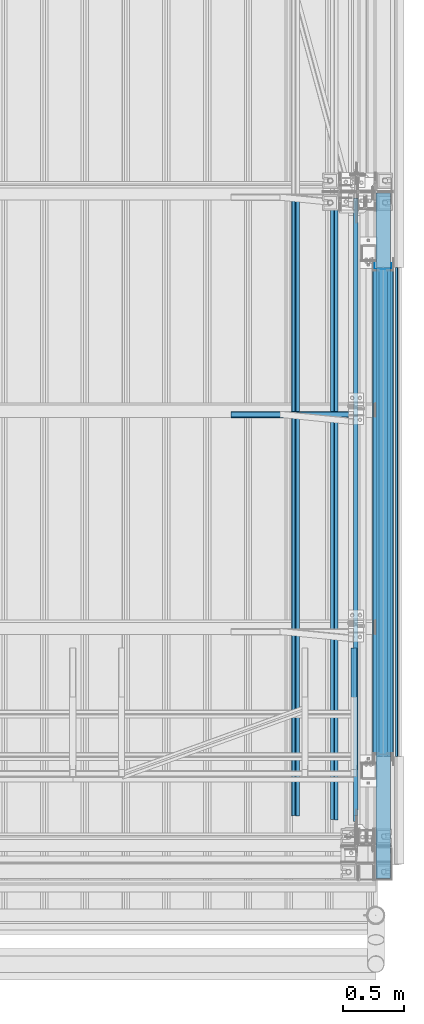
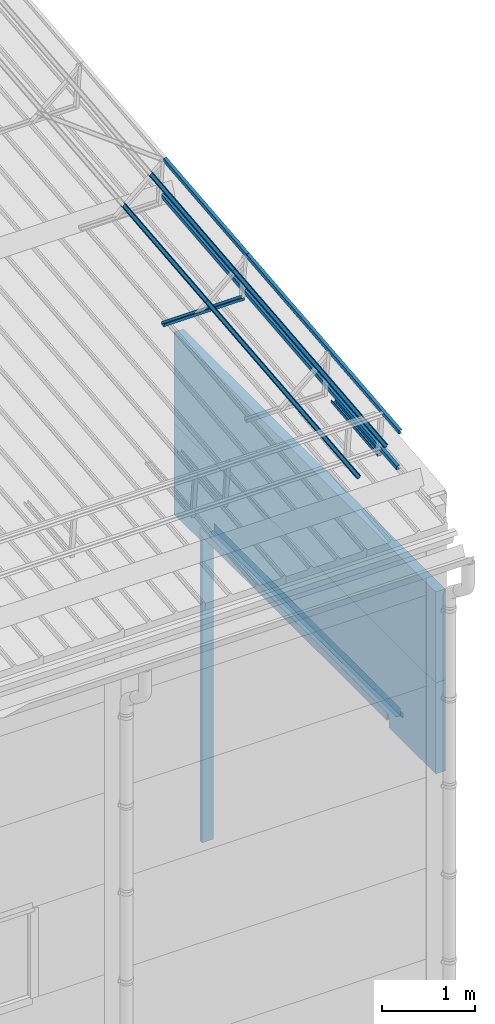
# One storey, part 71 of 709: 17 beams, 1 opening, 17 elements without a shape of their own.
"""IFC4 building model written with IfcOpenShell, lengths in millimetres."""

from ifc_helpers import new_model, si_unit, direction, frame, origin_with_axes, place, context, subcontext, project, spatial, line, indexed_curve, outline, extrude, material, element, aggregate, save


model = new_model("IFC4")

# Units and contexts
model_context = context("Model", 3, precision=0.2, world=origin_with_axes(), true_north=direction((0.0, 1.0)))
body_context = subcontext(model_context, "Body", "Model", "MODEL_VIEW")
ifc_project = project(units=[si_unit("LENGTHUNIT", "METRE", prefix="MILLI"), si_unit("AREAUNIT", "SQUARE_METRE"), si_unit("VOLUMEUNIT", "CUBIC_METRE"), si_unit("MASSUNIT", "GRAM", prefix="KILO"), si_unit("TIMEUNIT", "SECOND"), si_unit("PLANEANGLEUNIT", "RADIAN"), si_unit("SOLIDANGLEUNIT", "STERADIAN"), si_unit("THERMODYNAMICTEMPERATUREUNIT", "DEGREE_CELSIUS"), si_unit("LUMINOUSINTENSITYUNIT", "LUMEN")], contexts=[model_context])

# Site, building, storey
site_placement = place(None, origin_with_axes())
site = spatial("IfcSite", under=ifc_project, at=site_placement, CompositionType="ELEMENT")
building_placement = place(site_placement, origin_with_axes())
building = spatial("IfcBuilding", under=site, at=building_placement, Name="Undefined", CompositionType="ELEMENT")
storey_placement = place(building_placement, origin_with_axes())
storey = spatial("IfcBuildingStorey", under=building, at=storey_placement, Name="Undefined", CompositionType="ELEMENT", Elevation=0.0)

# Assembly, beam
assembly_1_placement = place(storey_placement, frame((49820.0, 768.92298, 7577.16191), z_axis=(0.0, -0.099503719, 0.9950371902), x_axis=(0.0, 0.9950371902, 0.099503719)))
assembly_1 = element("IfcElementAssembly", 1, at=assembly_1_placement, inside=storey)
ifc_material_1 = material(Name="Steel_Undefined", Category="STEEL")
beam_1_placement = place(assembly_1_placement, origin_with_axes())
beam_1 = element("IfcBeam", 2, at=beam_1_placement, material=ifc_material_1, ObjectType="601", context=body_context, shape_type="SolidModel", body=[
    extrude(outline(indexed_curve([(-20.0, -25.0), (20.0, -25.0), (20.0, -22.5), (-17.5, -22.5), (-17.5, 22.5), (20.0, 22.5), (20.0, 25.0), (-20.0, 25.0)], segments=[line(1, 2, 3, 4, 5, 6, 7, 8, 1)])), frame((0.0, 0.0, 0.0), z_axis=(-1.0, 0.0, 0.0), x_axis=(0.0, 0.0, 1.0)), (0.0, 0.0, -1.0), 1000.0),
])
aggregate(assembly_1, [beam_1])

assembly_2_placement = place(storey_placement, frame((49815.0, 3676.5335, 7867.92296), z_axis=(0.0, -0.099503719, 0.9950371902), x_axis=(-1.0, 0.0, 0.0)))
assembly_2 = element("IfcElementAssembly", 3, at=assembly_2_placement, inside=storey)
beam_2_placement = place(assembly_2_placement, origin_with_axes())
beam_2 = element("IfcBeam", 4, at=beam_2_placement, material=ifc_material_1, ObjectType="601", context=body_context, shape_type="SolidModel", body=[
    extrude(outline(indexed_curve([(-20.0, -25.0), (20.0, -25.0), (20.0, -22.5), (-17.5, -22.5), (-17.5, 22.5), (20.0, 22.5), (20.0, 25.0), (-20.0, 25.0)], segments=[line(1, 2, 3, 4, 5, 6, 7, 8, 1)])), frame((0.0, 0.0, 0.0), z_axis=(-1.0, 0.0, 0.0), x_axis=(0.0, 0.0, 1.0)), (0.0, 0.0, -1.0), 1000.0),
])
aggregate(assembly_2, [beam_2])

assembly_3_placement = place(storey_placement, frame((49835.0, 349.56581, 8118.11898), z_axis=(1.0, 0.0, 0.0), x_axis=(0.0, 0.9950371902, 0.099503719)))
assembly_3 = element("IfcElementAssembly", 5, at=assembly_3_placement, inside=storey)
beam_3_placement = place(assembly_3_placement, origin_with_axes())
beam_3 = element("IfcBeam", 6, at=beam_3_placement, material=ifc_material_1, ObjectType="608", context=body_context, shape_type="SolidModel", body=[
    extrude(outline(indexed_curve([(-20.0, -25.0), (20.0, -25.0), (20.0, -22.5), (-17.5, -22.5), (-17.5, 22.5), (20.0, 22.5), (20.0, 25.0), (-20.0, 25.0)], segments=[line(1, 2, 3, 4, 5, 6, 7, 8, 1)])), frame((0.0, 0.0, 0.0), z_axis=(-1.0, 0.0, 0.0), x_axis=(0.0, 0.0, 1.0)), (0.0, 0.0, -1.0), 3285.56115),
])
aggregate(assembly_3, [beam_3])

assembly_4_placement = place(storey_placement, frame((49835.0, 399.31767, 7620.60038), z_axis=(1.0, 0.0, 0.0), x_axis=(0.0, 0.9950371902, 0.099503719)))
assembly_4 = element("IfcElementAssembly", 7, at=assembly_4_placement, inside=storey)
beam_4_placement = place(assembly_4_placement, origin_with_axes())
beam_4 = element("IfcBeam", 8, at=beam_4_placement, material=ifc_material_1, ObjectType="608", context=body_context, shape_type="SolidModel", body=[
    extrude(outline(indexed_curve([(-20.0, -25.0), (20.0, -25.0), (20.0, -22.5), (-17.5, -22.5), (-17.5, 22.5), (20.0, 22.5), (20.0, 25.0), (-20.0, 25.0)], segments=[line(1, 2, 3, 4, 5, 6, 7, 8, 1)])), frame((0.0, 0.0, 0.0), z_axis=(-1.0, 0.0, 0.0), x_axis=(0.0, 0.0, 1.0)), (0.0, 0.0, -1.0), 3285.56115),
])
aggregate(assembly_4, [beam_4])

assembly_5_placement = place(storey_placement, frame((49659.43651, 362.23056, 7991.47142), z_axis=(-0.707106781, -0.070359754, 0.703597545), x_axis=(0.0, 0.9950371902, 0.099503719)))
assembly_5 = element("IfcElementAssembly", 9, at=assembly_5_placement, inside=storey)
beam_5_placement = place(assembly_5_placement, origin_with_axes())
beam_5 = element("IfcBeam", 10, at=beam_5_placement, material=ifc_material_1, ObjectType="608", context=body_context, shape_type="SolidModel", body=[
    extrude(outline(indexed_curve([(-20.0, -25.0), (20.0, -25.0), (20.0, -22.5), (-17.5, -22.5), (-17.5, 22.5), (20.0, 22.5), (20.0, 25.0), (-20.0, 25.0)], segments=[line(1, 2, 3, 4, 5, 6, 7, 8, 1)])), frame((0.0, 0.0, 0.0), z_axis=(-1.0, 0.0, 0.0), x_axis=(0.0, 0.0, 1.0)), (0.0, 0.0, -1.0), 3285.56115),
])
aggregate(assembly_5, [beam_5])

assembly_6_placement = place(storey_placement, frame((49342.27922, 393.78889, 7675.88813), z_axis=(-0.707106781, -0.070359754, 0.703597545), x_axis=(0.0, 0.9950371902, 0.099503719)))
assembly_6 = element("IfcElementAssembly", 11, at=assembly_6_placement, inside=storey)
beam_6_placement = place(assembly_6_placement, origin_with_axes())
beam_6 = element("IfcBeam", 12, at=beam_6_placement, material=ifc_material_1, ObjectType="608", context=body_context, shape_type="SolidModel", body=[
    extrude(outline(indexed_curve([(-20.0, -25.0), (20.0, -25.0), (20.0, -22.5), (-17.5, -22.5), (-17.5, 22.5), (20.0, 22.5), (20.0, 25.0), (-20.0, 25.0)], segments=[line(1, 2, 3, 4, 5, 6, 7, 8, 1)])), frame((0.0, 0.0, 0.0), z_axis=(-1.0, 0.0, 0.0), x_axis=(0.0, 0.0, 1.0)), (0.0, 0.0, -1.0), 3285.56115),
])
aggregate(assembly_6, [beam_6])

assembly_7_placement = place(storey_placement, frame((49835.0, 3618.82134, 8445.04453), z_axis=(1.0, 0.0, 0.0), x_axis=(0.0, 0.9950371902, 0.099503719)))
assembly_7 = element("IfcElementAssembly", 13, at=assembly_7_placement, inside=storey)
beam_7_placement = place(assembly_7_placement, origin_with_axes())
beam_7 = element("IfcBeam", 14, at=beam_7_placement, material=ifc_material_1, ObjectType="609", context=body_context, shape_type="SolidModel", body=[
    extrude(outline(indexed_curve([(-20.0, -25.0), (20.0, -25.0), (20.0, -22.5), (-17.5, -22.5), (-17.5, 22.5), (20.0, 22.5), (20.0, 25.0), (-20.0, 25.0)], segments=[line(1, 2, 3, 4, 5, 6, 7, 8, 1)])), frame((0.0, 0.0, 0.0), z_axis=(-1.0, 0.0, 0.0), x_axis=(0.0, 0.0, 1.0)), (0.0, 0.0, -1.0), 1785.56115),
])
aggregate(assembly_7, [beam_7])

assembly_8_placement = place(storey_placement, frame((49835.0, 3668.5732, 7947.52594), z_axis=(1.0, 0.0, 0.0), x_axis=(0.0, 0.9950371902, 0.099503719)))
assembly_8 = element("IfcElementAssembly", 15, at=assembly_8_placement, inside=storey)
beam_8_placement = place(assembly_8_placement, origin_with_axes())
beam_8 = element("IfcBeam", 16, at=beam_8_placement, material=ifc_material_1, ObjectType="609", context=body_context, shape_type="SolidModel", body=[
    extrude(outline(indexed_curve([(-20.0, -25.0), (20.0, -25.0), (20.0, -22.5), (-17.5, -22.5), (-17.5, 22.5), (20.0, 22.5), (20.0, 25.0), (-20.0, 25.0)], segments=[line(1, 2, 3, 4, 5, 6, 7, 8, 1)])), frame((0.0, 0.0, 0.0), z_axis=(-1.0, 0.0, 0.0), x_axis=(0.0, 0.0, 1.0)), (0.0, 0.0, -1.0), 1785.56115),
])
aggregate(assembly_8, [beam_8])

assembly_9_placement = place(storey_placement, frame((49659.43651, 3631.4861, 8318.39698), z_axis=(-0.707106781, -0.070359754, 0.703597545), x_axis=(0.0, 0.9950371902, 0.099503719)))
assembly_9 = element("IfcElementAssembly", 17, at=assembly_9_placement, inside=storey)
beam_9_placement = place(assembly_9_placement, origin_with_axes())
beam_9 = element("IfcBeam", 18, at=beam_9_placement, material=ifc_material_1, ObjectType="609", context=body_context, shape_type="SolidModel", body=[
    extrude(outline(indexed_curve([(-20.0, -25.0), (20.0, -25.0), (20.0, -22.5), (-17.5, -22.5), (-17.5, 22.5), (20.0, 22.5), (20.0, 25.0), (-20.0, 25.0)], segments=[line(1, 2, 3, 4, 5, 6, 7, 8, 1)])), frame((0.0, 0.0, 0.0), z_axis=(-1.0, 0.0, 0.0), x_axis=(0.0, 0.0, 1.0)), (0.0, 0.0, -1.0), 1785.56115),
])
aggregate(assembly_9, [beam_9])

assembly_10_placement = place(storey_placement, frame((49342.27922, 3663.04443, 8002.81368), z_axis=(-0.707106781, -0.070359754, 0.703597545), x_axis=(0.0, 0.9950371902, 0.099503719)))
assembly_10 = element("IfcElementAssembly", 19, at=assembly_10_placement, inside=storey)
beam_10_placement = place(assembly_10_placement, origin_with_axes())
beam_10 = element("IfcBeam", 20, at=beam_10_placement, material=ifc_material_1, ObjectType="609", context=body_context, shape_type="SolidModel", body=[
    extrude(outline(indexed_curve([(-20.0, -25.0), (20.0, -25.0), (20.0, -22.5), (-17.5, -22.5), (-17.5, 22.5), (20.0, 22.5), (20.0, 25.0), (-20.0, 25.0)], segments=[line(1, 2, 3, 4, 5, 6, 7, 8, 1)])), frame((0.0, 0.0, 0.0), z_axis=(-1.0, 0.0, 0.0), x_axis=(0.0, 0.0, 1.0)), (0.0, 0.0, -1.0), 1785.56115),
])
aggregate(assembly_10, [beam_10])

# Assembly, beam, voiding feature
assembly_11_placement = place(storey_placement, frame((50060.0, -120.0, 4465.0), z_axis=(0.0, 0.0, -1.0), x_axis=(0.0, 1.0, 0.0)))
assembly_11 = element("IfcElementAssembly", 21, at=assembly_11_placement, inside=storey)
ifc_material_2 = material(Name="Insulation", Category="Insulation")
beam_11_placement = place(assembly_11_placement, origin_with_axes())
beam_11 = element("IfcBeam", 22, at=beam_11_placement, material=ifc_material_2, ObjectType="P-142", context=body_context, shape_type="SolidModel", body=[
    extrude(outline(indexed_curve([(-595.0, -60.0), (595.0, -60.0), (595.0, 60.0), (-595.0, 60.0)], segments=[line(1, 2, 3, 4, 1)])), frame((0.0, 0.0, 0.0), z_axis=(-1.0, 0.0, 0.0), x_axis=(0.0, 0.0, 1.0)), (0.0, 0.0, -1.0), 5610.0),
])
voiding_feature_placement = place(beam_11_placement, frame((1000.0, 0.0, 465.0), z_axis=(0.0, 1.0, 0.0), x_axis=(0.0, 0.0, 1.0)))
element("IfcVoidingFeature", 23, at=voiding_feature_placement, cuts=beam_11, Name="opening", PredefinedType="HOLE", context=body_context, shape_type="SolidModel", body=[
    extrude(outline(indexed_curve([(0.0, 0.0), (4050.0, 0.0), (4050.0, 4000.0), (0.0, 4000.0)], segments=[line(1, 2, 3, 4, 1)])), frame((0.0, 0.0, 62.5), z_axis=(0.0, 0.0, 1.0), x_axis=(1.0, 0.0, 0.0)), (0.0, 0.0, -1.0), 125.0),
])
aggregate(assembly_11, [beam_11])

# Assembly, beam
assembly_12_placement = place(storey_placement, frame((50060.0, -120.0, 5655.0), z_axis=(0.0, 0.0, -1.0), x_axis=(0.0, 1.0, 0.0)))
assembly_12 = element("IfcElementAssembly", 24, at=assembly_12_placement, inside=storey)
beam_12_placement = place(assembly_12_placement, origin_with_axes())
beam_12 = element("IfcBeam", 25, at=beam_12_placement, material=ifc_material_2, ObjectType="P-130", context=body_context, shape_type="SolidModel", body=[
    extrude(outline(indexed_curve([(-595.0, -60.0), (595.0, -60.0), (595.0, 60.0), (-595.0, 60.0)], segments=[line(1, 2, 3, 4, 1)])), frame((0.0, 0.0, 0.0), z_axis=(-1.0, 0.0, 0.0), x_axis=(0.0, 0.0, 1.0)), (0.0, 0.0, -1.0), 5610.0),
])
aggregate(assembly_12, [beam_12])

assembly_13_placement = place(storey_placement, frame((49999.0, 4880.0, 3975.0), z_axis=(-1.0, 0.0, 0.0), x_axis=(0.0, -1.0, 0.0)))
assembly_13 = element("IfcElementAssembly", 26, at=assembly_13_placement, inside=storey)
beam_13_placement = place(assembly_13_placement, origin_with_axes())
beam_13 = element("IfcBeam", 27, at=beam_13_placement, material=ifc_material_1, context=body_context, shape_type="SolidModel", body=[
    extrude(outline(indexed_curve([(-25.0, -1.0), (25.0, -1.0), (25.0, 99.0), (23.0, 99.0), (23.0, 1.0), (-25.0, 1.0)], segments=[line(1, 2, 3, 4, 5, 6, 1)])), frame((0.0, 0.0, 0.0), z_axis=(-1.0, 0.0, 0.0), x_axis=(0.0, 0.0, 1.0)), (0.0, 0.0, -1.0), 4000.0),
])
aggregate(assembly_13, [beam_13])

assembly_14_placement = place(storey_placement, frame((50119.0, 880.0, 3975.0), z_axis=(1.0, 0.0, 0.0), x_axis=(0.0, 1.0, 0.0)))
assembly_14 = element("IfcElementAssembly", 28, at=assembly_14_placement, inside=storey)
beam_14_placement = place(assembly_14_placement, origin_with_axes())
beam_14 = element("IfcBeam", 29, at=beam_14_placement, material=ifc_material_1, context=body_context, shape_type="SolidModel", body=[
    extrude(outline(indexed_curve([(-25.0, -1.0), (25.0, -1.0), (25.0, 99.0), (23.0, 99.0), (23.0, 1.0), (-25.0, 1.0)], segments=[line(1, 2, 3, 4, 5, 6, 1)])), frame((0.0, 0.0, 0.0), z_axis=(-1.0, 0.0, 0.0), x_axis=(0.0, 0.0, 1.0)), (0.0, 0.0, -1.0), 4000.0),
])
aggregate(assembly_14, [beam_14])

assembly_15_placement = place(storey_placement, frame((50060.0, 880.0, 4020.0), z_axis=(-1.0, 0.0, 0.0), x_axis=(0.0, 1.0, 0.0)))
assembly_15 = element("IfcElementAssembly", 30, at=assembly_15_placement, inside=storey)
beam_15_placement = place(assembly_15_placement, origin_with_axes())
beam_15 = element("IfcBeam", 31, at=beam_15_placement, material=ifc_material_1, context=body_context, shape_type="SolidModel", body=[
    extrude(outline(indexed_curve([(-70.0, -25.0), (-68.0, -25.0), (-68.0, 23.0), (68.0, 23.0), (68.0, -25.0), (70.0, -25.0), (70.0, 25.0), (-70.0, 25.0)], segments=[line(1, 2, 3, 4, 5, 6, 7, 8, 1)])), frame((0.0, 0.0, 0.0), z_axis=(-1.0, 0.0, 0.0), x_axis=(0.0, 0.0, 1.0)), (0.0, 0.0, -1.0), 4000.0),
])
aggregate(assembly_15, [beam_15])

assembly_16_placement = place(storey_placement, frame((50169.0, 880.0, 3940.0), z_axis=(1.0, 0.0, 0.0), x_axis=(0.0, 1.0, 0.0)))
assembly_16 = element("IfcElementAssembly", 32, at=assembly_16_placement, inside=storey)
beam_16_placement = place(assembly_16_placement, origin_with_axes())
beam_16 = element("IfcBeam", 33, at=beam_16_placement, material=ifc_material_1, context=body_context, shape_type="SolidModel", body=[
    extrude(outline(indexed_curve([(-10.0, -1.0), (10.0, -1.0), (10.0, 49.0), (8.0, 49.0), (8.0, 1.0), (-10.0, 1.0)], segments=[line(1, 2, 3, 4, 5, 6, 1)])), frame((0.0, 0.0, 0.0), z_axis=(-1.0, 0.0, 0.0), x_axis=(0.0, 0.0, 1.0)), (0.0, 0.0, -1.0), 4000.0),
])
aggregate(assembly_16, [beam_16])

assembly_17_placement = place(storey_placement, frame((50060.0, 4890.0, 4000.0), z_axis=(-1.0, 0.0, 0.0), x_axis=(0.0, 0.0, -1.0)))
assembly_17 = element("IfcElementAssembly", 34, at=assembly_17_placement, inside=storey)
beam_17_placement = place(assembly_17_placement, origin_with_axes())
beam_17 = element("IfcBeam", 35, at=beam_17_placement, material=ifc_material_1, context=body_context, shape_type="SolidModel", body=[
    extrude(outline(indexed_curve([(-70.0, -25.0), (-68.0, -25.0), (-68.0, 23.0), (68.0, 23.0), (68.0, -25.0), (70.0, -25.0), (70.0, 25.0), (-70.0, 25.0)], segments=[line(1, 2, 3, 4, 5, 6, 7, 8, 1)])), frame((0.0, 0.0, 0.0), z_axis=(-1.0, 0.0, 0.0), x_axis=(0.0, 0.0, 1.0)), (0.0, 0.0, -1.0), 4050.0),
])
aggregate(assembly_17, [beam_17])

save(model, "model.ifc")
